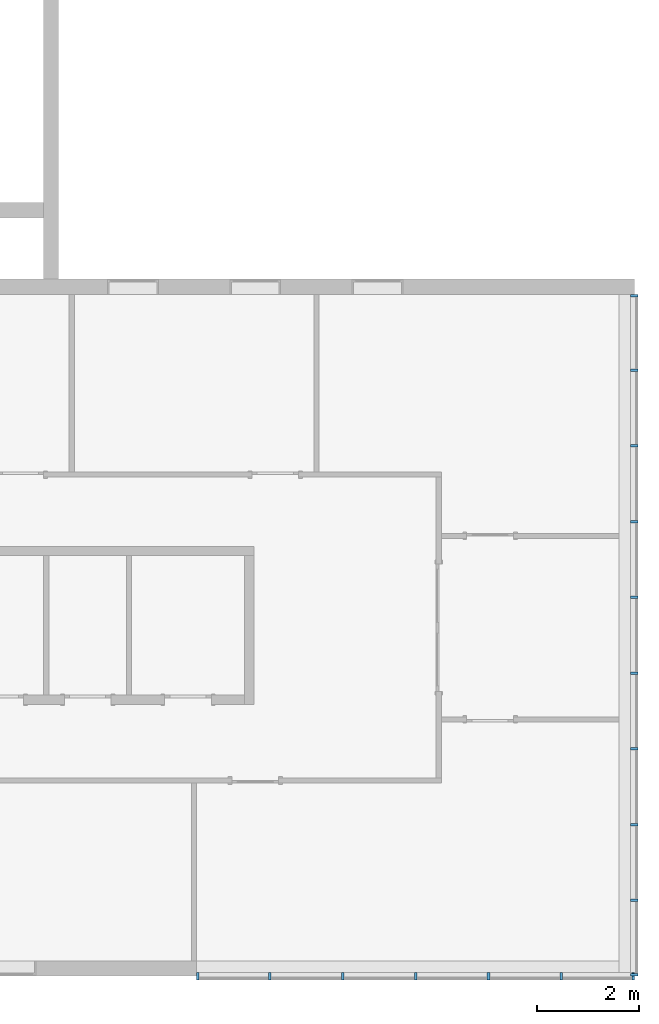
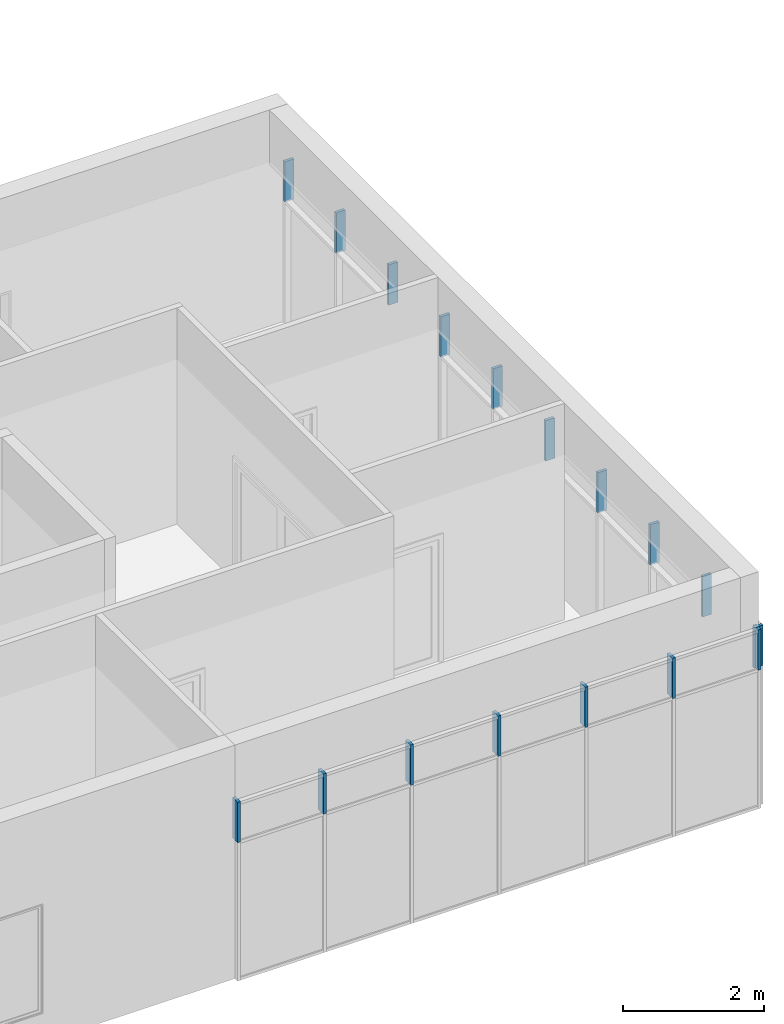
# One storey, part 7 of 13: 17 members, 2 elements without a shape of their own.
"""IFC2X3 building model written with IfcOpenShell, lengths in millimetres."""

from ifc_helpers import new_model, entity, si_unit, converted_unit, derived_unit, direction, frame, frame_2d, origin, origin_2d_with_axis, place, context, subcontext, project, spatial, rectangle, extrude, material, type_object, element, aggregate, save


model = new_model("IFC2X3")

# Units and contexts
model_context = context("Model", 3, precision=0.01, world=origin(), true_north=direction((6.12303176911189e-17, 1.0)))
context_of_model = context(None, 3, precision=0.01, world=origin(), true_north=direction((6.12303176911189e-17, 1.0)))
body_context = subcontext(model_context, "Body", "Model", "MODEL_VIEW")
ifc_project = project(units=[si_unit("LENGTHUNIT", "METRE", prefix="MILLI"), si_unit("AREAUNIT", "SQUARE_METRE"), si_unit("VOLUMEUNIT", "CUBIC_METRE"), converted_unit("PLANEANGLEUNIT", "DEGREE", entity("IfcRatioMeasure", 0.0174532925199433), si_unit("PLANEANGLEUNIT", "RADIAN"), dimensions=[0, 0, 0, 0, 0, 0, 0]), si_unit("MASSUNIT", "GRAM", prefix="KILO"), si_unit("TIMEUNIT", "SECOND"), si_unit("FREQUENCYUNIT", "HERTZ"), si_unit("THERMODYNAMICTEMPERATUREUNIT", "DEGREE_CELSIUS"), derived_unit("THERMALTRANSMITTANCEUNIT", [(si_unit("MASSUNIT", "GRAM", prefix="KILO"), 1), (si_unit("THERMODYNAMICTEMPERATUREUNIT", "KELVIN"), -1), (si_unit("TIMEUNIT", "SECOND"), -3)]), derived_unit("VOLUMETRICFLOWRATEUNIT", [(si_unit("LENGTHUNIT", "METRE"), 3), (si_unit("TIMEUNIT", "SECOND"), -1)]), si_unit("ELECTRICCURRENTUNIT", "AMPERE"), si_unit("ELECTRICVOLTAGEUNIT", "VOLT"), si_unit("POWERUNIT", "WATT"), si_unit("FORCEUNIT", "NEWTON", prefix="KILO"), si_unit("ILLUMINANCEUNIT", "LUX"), si_unit("LUMINOUSFLUXUNIT", "LUMEN"), si_unit("LUMINOUSINTENSITYUNIT", "CANDELA"), si_unit("PRESSUREUNIT", "PASCAL")], contexts=[model_context, context_of_model])

# Site, building, storey
site_placement = place(None, origin())
site = spatial("IfcSite", under=ifc_project, at=site_placement, CompositionType="ELEMENT")
building_placement = place(site_placement, origin())
building = spatial("IfcBuilding", under=site, at=building_placement, CompositionType="ELEMENT")
storey_placement = place(building_placement, frame((0.0, 0.0, 3750.0)))
storey = spatial("IfcBuildingStorey", under=building, at=storey_placement, Name="02. 2 etg.", CompositionType="ELEMENT", Elevation=3750.00000000068)

# Curtain wall, members
curtain_wall_type = type_object("IfcCurtainWallType", Name="Curtain Wall:Storefront", PredefinedType="NOTDEFINED")
curtain_wall_1_placement = place(storey_placement, frame((0.0, 0.0, -3750.0)))
curtain_wall_1 = element("IfcCurtainWall", 1, at=curtain_wall_1_placement, inside=storey, type_object=curtain_wall_type, Name="Curtain Wall:Storefront", ObjectType="Curtain Wall:Storefront")
ifc_material = material(Name="Aluminium")
member_1_placement = place(curtain_wall_1_placement, frame((41023.2357123495, -110.0, 5850.0)))
member_1 = element("IfcMember", 2, at=member_1_placement, material=ifc_material, Name="Curtain Wall:Storefront:8486", ObjectType="Curtain Wall:Storefront:8486", context=body_context, shape_type="SweptSolid", body=[
    extrude(rectangle(XDim=50.0, YDim=150.000000000001, at=origin_2d_with_axis()), frame((75.0, 25.0, 0.0), z_axis=(0.0, 0.0, 1.0), x_axis=(0.0, -1.0, 0.0)), (0.0, 0.0, 1.0), 700.000000000001),
])
member_2_placement = place(curtain_wall_1_placement, frame((41023.2357123495, -13440.0, 5850.0)))
member_2 = element("IfcMember", 3, at=member_2_placement, material=ifc_material, Name="Curtain Wall:Storefront:8486", ObjectType="Curtain Wall:Storefront:8486", context=body_context, shape_type="SweptSolid", body=[
    extrude(rectangle(XDim=150.000000000001, YDim=49.9999999999995, at=frame_2d((0.0, -1.08357767203415e-12), x_axis=(1.0, 0.0))), frame((75.0, 25.0, 0.0)), (0.0, 0.0, 1.0), 700.000000000001),
])
member_3_placement = place(curtain_wall_1_placement, frame((41023.2357123495, -1571.66666666667, 5850.0)))
member_3 = element("IfcMember", 4, at=member_3_placement, material=ifc_material, Name="Curtain Wall:Storefront:8486", ObjectType="Curtain Wall:Storefront:8486", context=body_context, shape_type="SweptSolid", body=[
    extrude(rectangle(XDim=150.000000000001, YDim=50.0, at=origin_2d_with_axis()), frame((75.0, 25.0, 0.0)), (0.0, 0.0, 1.0), 700.000000000001),
])
member_4_placement = place(curtain_wall_1_placement, frame((41023.2357123495, -3058.33333333333, 5850.0)))
member_4 = element("IfcMember", 5, at=member_4_placement, material=ifc_material, Name="Curtain Wall:Storefront:8486", ObjectType="Curtain Wall:Storefront:8486", context=body_context, shape_type="SweptSolid", body=[
    extrude(rectangle(XDim=150.000000000001, YDim=50.0, at=origin_2d_with_axis()), frame((75.0, 25.0, 0.0)), (0.0, 0.0, 1.0), 700.000000000001),
])
member_5_placement = place(curtain_wall_1_placement, frame((41023.2357123495, -4545.0, 5850.0)))
member_5 = element("IfcMember", 6, at=member_5_placement, material=ifc_material, Name="Curtain Wall:Storefront:8486", ObjectType="Curtain Wall:Storefront:8486", context=body_context, shape_type="SweptSolid", body=[
    extrude(rectangle(XDim=150.000000000001, YDim=50.0, at=origin_2d_with_axis()), frame((75.0, 25.0, 0.0)), (0.0, 0.0, 1.0), 700.000000000001),
])
member_6_placement = place(curtain_wall_1_placement, frame((41023.2357123495, -6031.66666666667, 5850.0)))
member_6 = element("IfcMember", 7, at=member_6_placement, material=ifc_material, Name="Curtain Wall:Storefront:8486", ObjectType="Curtain Wall:Storefront:8486", context=body_context, shape_type="SweptSolid", body=[
    extrude(rectangle(XDim=150.000000000001, YDim=49.9999999999995, at=origin_2d_with_axis()), frame((75.0, 25.0, 0.0)), (0.0, 0.0, 1.0), 700.000000000001),
])
member_7_placement = place(curtain_wall_1_placement, frame((41023.2357123495, -7518.33333333333, 5850.0)))
member_7 = element("IfcMember", 8, at=member_7_placement, material=ifc_material, Name="Curtain Wall:Storefront:8486", ObjectType="Curtain Wall:Storefront:8486", context=body_context, shape_type="SweptSolid", body=[
    extrude(rectangle(XDim=150.000000000001, YDim=49.9999999999995, at=origin_2d_with_axis()), frame((75.0, 25.0, 0.0)), (0.0, 0.0, 1.0), 700.000000000001),
])
member_8_placement = place(curtain_wall_1_placement, frame((41023.2357123495, -9005.0, 5850.0)))
member_8 = element("IfcMember", 9, at=member_8_placement, material=ifc_material, Name="Curtain Wall:Storefront:8486", ObjectType="Curtain Wall:Storefront:8486", context=body_context, shape_type="SweptSolid", body=[
    extrude(rectangle(XDim=150.000000000001, YDim=49.9999999999995, at=origin_2d_with_axis()), frame((75.0, 25.0, 0.0)), (0.0, 0.0, 1.0), 700.000000000001),
])
member_9_placement = place(curtain_wall_1_placement, frame((41023.2357123495, -10491.6666666667, 5850.0)))
member_9 = element("IfcMember", 10, at=member_9_placement, material=ifc_material, Name="Curtain Wall:Storefront:8486", ObjectType="Curtain Wall:Storefront:8486", context=body_context, shape_type="SweptSolid", body=[
    extrude(rectangle(XDim=150.000000000001, YDim=50.0000000000016, at=origin_2d_with_axis()), frame((75.0, 25.0, 0.0)), (0.0, 0.0, 1.0), 700.000000000001),
])
member_10_placement = place(curtain_wall_1_placement, frame((41023.2357123495, -11978.3333333333, 5850.0)))
member_10 = element("IfcMember", 11, at=member_10_placement, material=ifc_material, Name="Curtain Wall:Storefront:8486", ObjectType="Curtain Wall:Storefront:8486", context=body_context, shape_type="SweptSolid", body=[
    extrude(rectangle(XDim=150.000000000001, YDim=50.0000000000016, at=origin_2d_with_axis()), frame((75.0, 25.0, 0.0)), (0.0, 0.0, 1.0), 700.000000000001),
])
aggregate(curtain_wall_1, [member_1, member_2, member_3, member_4, member_5, member_6, member_7, member_8, member_9, member_10])

curtain_wall_2_placement = place(storey_placement, frame((0.0, 0.0, -3750.0)))
curtain_wall_2 = element("IfcCurtainWall", 12, at=curtain_wall_2_placement, inside=storey, type_object=curtain_wall_type, Name="Curtain Wall:Storefront", ObjectType="Curtain Wall:Storefront")
member_11_placement = place(curtain_wall_2_placement, frame((41048.2357123495, -13515.0, 5850.0)))
member_11 = element("IfcMember", 13, at=member_11_placement, material=ifc_material, Name="Curtain Wall:Storefront:8486", ObjectType="Curtain Wall:Storefront:8486", context=body_context, shape_type="SweptSolid", body=[
    extrude(rectangle(XDim=49.9999999999973, YDim=150.000000000001, at=frame_2d((4.33253433129721e-12, 0.0), x_axis=(1.0, 0.0))), frame((25.0, 75.0, 0.0), z_axis=(0.0, 0.0, 1.0), x_axis=(-1.0, 0.0, 0.0)), (0.0, 0.0, 1.0), 700.000000000001),
])
member_12_placement = place(curtain_wall_2_placement, frame((32508.2357123495, -13515.0, 5850.0)))
member_12 = element("IfcMember", 14, at=member_12_placement, material=ifc_material, Name="Curtain Wall:Storefront:8486", ObjectType="Curtain Wall:Storefront:8486", context=body_context, shape_type="SweptSolid", body=[
    extrude(rectangle(XDim=150.000000000001, YDim=50.0000000000016, at=frame_2d((-1.08002495835535e-12, -2.16715534406831e-12), x_axis=(1.0, 0.0))), frame((25.0, 75.0, 0.0), z_axis=(0.0, 0.0, 1.0), x_axis=(0.0, -1.0, 0.0)), (0.0, 0.0, 1.0), 700.000000000001),
])
member_13_placement = place(curtain_wall_2_placement, frame((39641.5690456828, -13515.0, 5850.0)))
member_13 = element("IfcMember", 15, at=member_13_placement, material=ifc_material, Name="Curtain Wall:Storefront:8486", ObjectType="Curtain Wall:Storefront:8486", context=body_context, shape_type="SweptSolid", body=[
    extrude(rectangle(XDim=150.000000000001, YDim=50.000000000006, at=frame_2d((-1.08002495835535e-12, 0.0), x_axis=(1.0, 0.0))), frame((25.0, 75.0, 0.0), z_axis=(0.0, 0.0, 1.0), x_axis=(0.0, -1.0, 0.0)), (0.0, 0.0, 1.0), 700.000000000001),
])
member_14_placement = place(curtain_wall_2_placement, frame((38209.9023790161, -13515.0, 5850.0)))
member_14 = element("IfcMember", 16, at=member_14_placement, material=ifc_material, Name="Curtain Wall:Storefront:8486", ObjectType="Curtain Wall:Storefront:8486", context=body_context, shape_type="SweptSolid", body=[
    extrude(rectangle(XDim=150.000000000001, YDim=49.9999999999973, at=frame_2d((-1.08002495835535e-12, 0.0), x_axis=(1.0, 0.0))), frame((25.0, 75.0, 0.0), z_axis=(0.0, 0.0, 1.0), x_axis=(0.0, -1.0, 0.0)), (0.0, 0.0, 1.0), 700.000000000001),
])
member_15_placement = place(curtain_wall_2_placement, frame((36778.2357123495, -13515.0, 5850.0)))
member_15 = element("IfcMember", 17, at=member_15_placement, material=ifc_material, Name="Curtain Wall:Storefront:8486", ObjectType="Curtain Wall:Storefront:8486", context=body_context, shape_type="SweptSolid", body=[
    extrude(rectangle(XDim=150.000000000001, YDim=49.9999999999973, at=frame_2d((-1.08002495835535e-12, 0.0), x_axis=(1.0, 0.0))), frame((25.0, 75.0, 0.0), z_axis=(0.0, 0.0, 1.0), x_axis=(0.0, -1.0, 0.0)), (0.0, 0.0, 1.0), 700.000000000001),
])
member_16_placement = place(curtain_wall_2_placement, frame((35346.5690456828, -13515.0, 5850.0)))
member_16 = element("IfcMember", 18, at=member_16_placement, material=ifc_material, Name="Curtain Wall:Storefront:8486", ObjectType="Curtain Wall:Storefront:8486", context=body_context, shape_type="SweptSolid", body=[
    extrude(rectangle(XDim=150.000000000001, YDim=49.9999999999973, at=frame_2d((-1.08002495835535e-12, 0.0), x_axis=(1.0, 0.0))), frame((25.0, 75.0, 0.0), z_axis=(0.0, 0.0, 1.0), x_axis=(0.0, -1.0, 0.0)), (0.0, 0.0, 1.0), 700.000000000001),
])
member_17_placement = place(curtain_wall_2_placement, frame((33914.9023790161, -13515.0, 5850.0)))
member_17 = element("IfcMember", 19, at=member_17_placement, material=ifc_material, Name="Curtain Wall:Storefront:8486", ObjectType="Curtain Wall:Storefront:8486", context=body_context, shape_type="SweptSolid", body=[
    extrude(rectangle(XDim=150.000000000001, YDim=49.9999999999973, at=frame_2d((-1.08002495835535e-12, 0.0), x_axis=(1.0, 0.0))), frame((25.0, 75.0, 0.0), z_axis=(0.0, 0.0, 1.0), x_axis=(0.0, -1.0, 0.0)), (0.0, 0.0, 1.0), 700.000000000001),
])
aggregate(curtain_wall_2, [member_11, member_12, member_13, member_14, member_15, member_16, member_17])

save(model, "model.ifc")
